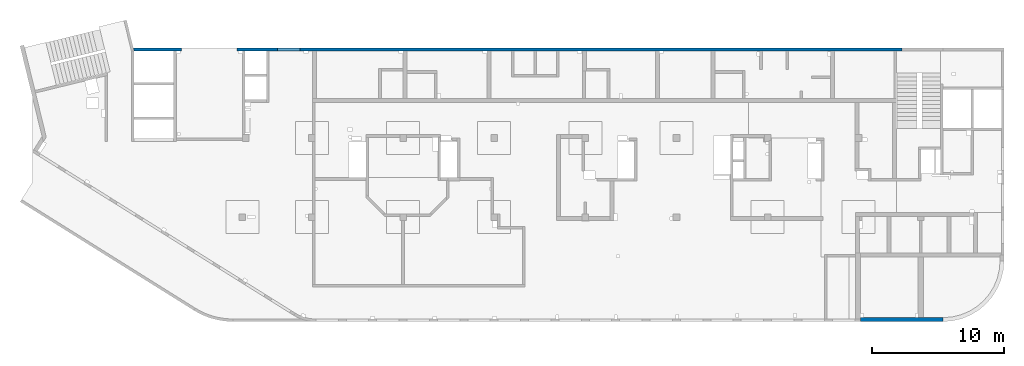
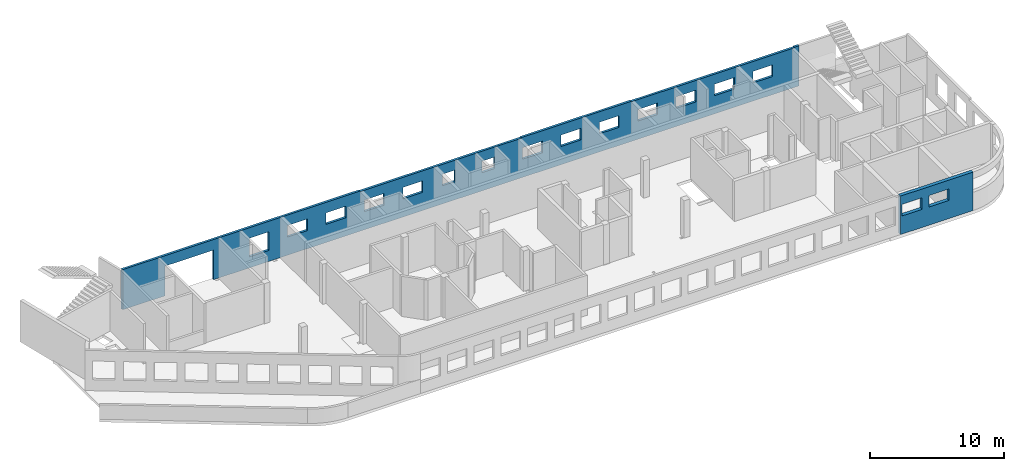
# One storey, part 9 of 10: 2 walls, 17 openings.
"""IFC4 building model written with IfcOpenShell, lengths in millimetres."""

import ifcopenshell
import ifcopenshell.guid

model = None  # the IFC model being written
_history = None  # IfcOwnerHistory: only IFC2X3 demands one
_inside = {}  # id of a spatial element -> (the spatial element, [elements in it])
_under = {}  # id of a project, library or spatial element -> (it, [spatial elements below it])
_declared = {}  # id of a project -> (the project, [libraries it declares])
_typed = {}  # id of a type object -> (the type object, [elements of that type])
_made_of = {}  # id of a material, layer set ... -> (it, [elements and type objects made of it])


def new_model(schema):
    """Start an empty IFC model of exactly this schema.

    Asked for "IFC4X3", IfcOpenShell would pick the latest addendum, in which some entities
    have other attributes; the version numbers below select the first issue.
    IFC2X3 requires an IfcOwnerHistory on every rooted entity: one is made here for all.
    """
    global model, _history
    if schema == "IFC4X3":
        model = ifcopenshell.file(schema_version=(4, 3, 0, 0))
    else:
        model = ifcopenshell.file(schema=schema)
    _inside.clear()
    _under.clear()
    _declared.clear()
    _typed.clear()
    _made_of.clear()
    _history = None
    if model.schema == "IFC2X3":
        org = make("IfcOrganization", Name="unknown")
        user = make(
            "IfcPersonAndOrganization",
            ThePerson=make("IfcPerson", FamilyName="unknown"),
            TheOrganization=org,
        )
        app = make(
            "IfcApplication",
            ApplicationDeveloper=org,
            Version="unknown",
            ApplicationFullName="unknown",
            ApplicationIdentifier="unknown",
        )
        _history = make(
            "IfcOwnerHistory",
            OwningUser=user,
            OwningApplication=app,
            ChangeAction="ADDED",
            CreationDate=0,
        )
    return model


def make(cls, **values):
    """One entity of the class cls with the attributes given. An attribute that is None is left unset."""
    return model.create_entity(
        cls, **{name: value for name, value in values.items() if value is not None}
    )


def entity(cls, *values):
    """Any entity or typed value of the class cls, its attributes in the order of the schema. None: left unset."""
    e = model.create_entity(cls)
    for i, value in enumerate(values):
        if value is not None:
            e[i] = value
    return e


def rooted(cls, **values):
    """An entity with a GlobalId (a new one), such as an element, a storey or a relation."""
    return make(cls, GlobalId=ifcopenshell.guid.new(), OwnerHistory=_history, **values)


def si_unit(unit_type, name, prefix=None):
    """IfcSIUnit, for example si_unit("LENGTHUNIT", "METRE", prefix="MILLI")."""
    return make("IfcSIUnit", UnitType=unit_type, Prefix=prefix, Name=name)


def converted_unit(unit_type, name, factor, base, dimensions=None, offset=None):
    """IfcConversionBasedUnit, such as the inch: factor (a typed value) times the base unit."""
    return make(
        "IfcConversionBasedUnit"
        if offset is None
        else "IfcConversionBasedUnitWithOffset",
        ConversionOffset=offset,
        Dimensions=None
        if dimensions is None
        else entity("IfcDimensionalExponents", *dimensions),
        UnitType=unit_type,
        Name=name,
        ConversionFactor=make(
            "IfcMeasureWithUnit", ValueComponent=factor, UnitComponent=base
        ),
    )


def derived_unit(unit_type, elements):
    """IfcDerivedUnit: a product of units, each with its exponent."""
    return make(
        "IfcDerivedUnit",
        Elements=[
            make("IfcDerivedUnitElement", Unit=unit, Exponent=power)
            for unit, power in elements
        ],
        UnitType=unit_type,
    )


def assignment(units):
    """IfcUnitAssignment: the units of a project."""
    return None if units is None else make("IfcUnitAssignment", Units=units)


def point(xyz):
    """IfcCartesianPoint."""
    return None if xyz is None else make("IfcCartesianPoint", Coordinates=xyz)


def direction(xyz):
    """IfcDirection."""
    return None if xyz is None else make("IfcDirection", DirectionRatios=xyz)


def frame(location, z_axis=None, x_axis=None):
    """IfcAxis2Placement3D, a coordinate frame: its origin and axes. An axis left out is left unset."""
    return make(
        "IfcAxis2Placement3D",
        Location=point(location),
        Axis=direction(z_axis),
        RefDirection=direction(x_axis),
    )


def origin():
    """The frame at (0, 0, 0) with its axes left unset."""
    return frame((0.0, 0.0, 0.0))


def place(relative_to, where):
    """IfcLocalPlacement: puts the frame where relative to a parent placement (None: the world)."""
    return make(
        "IfcLocalPlacement", PlacementRelTo=relative_to, RelativePlacement=where
    )


def context(
    kind, dimensions, precision=None, world=None, true_north=None, identifier=None
):
    """IfcGeometricRepresentationContext, for example the 3D "Model" context."""
    return make(
        "IfcGeometricRepresentationContext",
        ContextIdentifier=identifier,
        ContextType=kind,
        CoordinateSpaceDimension=dimensions,
        Precision=precision,
        WorldCoordinateSystem=world,
        TrueNorth=true_north,
    )


def subcontext(parent, identifier, kind, view, scale=None):
    """IfcGeometricRepresentationSubContext, for example "Body" below "Model"."""
    return make(
        "IfcGeometricRepresentationSubContext",
        ContextIdentifier=identifier,
        ContextType=kind,
        ParentContext=parent,
        TargetScale=scale,
        TargetView=view,
    )


def project(units=None, contexts=None):
    """IfcProject with its units and contexts."""
    return rooted(
        "IfcProject",
        Name="project",
        RepresentationContexts=contexts,
        UnitsInContext=assignment(units),
    )


def spatial(cls, under=None, at=None, **own):
    """A site, building, storey or space (cls), placed at a placement, below another one or the project."""
    s = rooted(cls, ObjectPlacement=at, **own)
    if under is not None:
        _under.setdefault(under.id(), (under, []))[1].append(s)
    return s


def point_list(points):
    """IfcCartesianPointList2D or 3D."""
    cls = (
        "IfcCartesianPointList2D" if len(points[0]) == 2 else "IfcCartesianPointList3D"
    )
    return make(cls, CoordList=points)


def indexed_curve(points, segments=None, self_intersect=None):
    """IfcIndexedPolyCurve: lines and arcs through numbered points (the first is 1)."""
    return make(
        "IfcIndexedPolyCurve",
        Points=point_list(points),
        Segments=segments,
        SelfIntersect=self_intersect,
    )


def outline(outer, holes=None, kind="AREA"):
    """IfcArbitraryClosedProfileDef: a profile drawn as a closed curve; with holes, ...WithVoids."""
    if holes is None:
        return make("IfcArbitraryClosedProfileDef", ProfileType=kind, OuterCurve=outer)
    return make(
        "IfcArbitraryProfileDefWithVoids",
        ProfileType=kind,
        OuterCurve=outer,
        InnerCurves=holes,
    )


def extrude(swept, where, along, depth):
    """IfcExtrudedAreaSolid: the profile swept, set in the frame where, extruded along a direction by depth."""
    return make(
        "IfcExtrudedAreaSolid",
        SweptArea=swept,
        Position=where,
        ExtrudedDirection=direction(along),
        Depth=depth,
    )


def polygons(points, faces, closed=None, point_numbers=None):
    """IfcPolygonalFaceSet: a face is its outer loop, then its inner loops; points numbered from 1."""
    made = []
    for loops in faces:
        if len(loops) == 1:
            made.append(make("IfcIndexedPolygonalFace", CoordIndex=loops[0]))
        else:
            made.append(
                make(
                    "IfcIndexedPolygonalFaceWithVoids",
                    CoordIndex=loops[0],
                    InnerCoordIndices=loops[1:],
                )
            )
    return make(
        "IfcPolygonalFaceSet",
        Coordinates=point_list(points),
        Closed=closed,
        Faces=made,
        PnIndex=point_numbers,
    )


def shape(context_of_items, identifier, shape_type, items):
    """IfcShapeRepresentation: the items that make up one representation, for example the "Body"."""
    return make(
        "IfcShapeRepresentation",
        ContextOfItems=context_of_items,
        RepresentationIdentifier=identifier,
        RepresentationType=shape_type,
        Items=items,
    )


def material(Name=None, Category=None):
    """IfcMaterial."""
    return make("IfcMaterial", Name=Name, Category=Category)


def made_of(thing, what):
    """Note that an element or type object is made of a material, layer set ...; save() writes the relation."""
    if what is not None:
        _made_of.setdefault(what.id(), (what, []))[1].append(thing)
    return thing


def type_object(cls, material=None, **own):
    """A type object (cls), such as IfcWallType, which elements share."""
    return made_of(rooted(cls, **own), material)


def element(
    cls,
    number,
    at=None,
    inside=None,
    cuts=None,
    type_object=None,
    material=None,
    context=None,
    identifier="Body",
    shape_type=None,
    held_by="IfcProductDefinitionShape",
    body=None,
    shapes=None,
    **own,
):
    """One element of the class cls, such as IfcWall. Its Tag is "e" and its number.

    at: its placement. inside: the storey or other place that contains it. cuts: it is an
    opening in that element (IfcRelVoidsElement). A single representation is given by context,
    identifier, shape_type and body (its items); several are given by shapes. held_by: the class
    of the entity that holds the representations. save() writes the other relations.
    """
    e = rooted(cls, Tag="e%d" % number, ObjectPlacement=at, **own)
    if body is not None:
        shapes = [shape(context, identifier, shape_type, body)]
    if shapes is not None:
        e.Representation = make(held_by, Representations=shapes)
    if inside is not None:
        _inside.setdefault(inside.id(), (inside, []))[1].append(e)
    if cuts is not None:
        rooted(
            "IfcRelVoidsElement", RelatingBuildingElement=cuts, RelatedOpeningElement=e
        )
    if type_object is not None:
        _typed.setdefault(type_object.id(), (type_object, []))[1].append(e)
    return made_of(e, material)


def aggregate(whole, parts):
    """IfcRelAggregates: a whole, such as a stair, and the parts it consists of."""
    return rooted("IfcRelAggregates", RelatingObject=whole, RelatedObjects=parts)


def save(model, path):
    """Write the relations noted so far, then the file.

    IfcRelAggregates (storeys below a building ...), IfcRelContainedInSpatialStructure (elements
    in a storey), IfcRelDefinesByType, IfcRelAssociatesMaterial and IfcRelDeclares: one each for
    every whole, place, type object, material and project.
    """
    for whole, parts in _under.values():
        aggregate(whole, parts)
    for where, things in _inside.values():
        rooted(
            "IfcRelContainedInSpatialStructure",
            RelatedElements=things,
            RelatingStructure=where,
        )
    for kind, things in _typed.values():
        rooted("IfcRelDefinesByType", RelatedObjects=things, RelatingType=kind)
    for what, things in _made_of.values():
        rooted("IfcRelAssociatesMaterial", RelatedObjects=things, RelatingMaterial=what)
    for by, libraries in _declared.values():
        rooted("IfcRelDeclares", RelatingContext=by, RelatedDefinitions=libraries)
    model.write(path)


model = new_model("IFC4")

# Units and contexts
model_context = context("Model", 3, precision=0.01, world=origin(), true_north=direction((6.12303176911189e-17, 1.0)))
plan_context = context("Plan", 3, precision=0.01, world=origin(), true_north=direction((6.12303176911189e-17, 1.0)))
body_context = subcontext(model_context, "Body", "Model", "MODEL_VIEW")
ifc_project = project(units=[si_unit("LENGTHUNIT", "METRE", prefix="MILLI"), si_unit("AREAUNIT", "SQUARE_METRE"), si_unit("VOLUMEUNIT", "CUBIC_METRE"), converted_unit("PLANEANGLEUNIT", "DEGREE", entity("IfcRatioMeasure", 0.0174532925199433), si_unit("PLANEANGLEUNIT", "RADIAN"), dimensions=[0, 0, 0, 0, 0, 0, 0]), si_unit("MASSUNIT", "GRAM", prefix="KILO"), derived_unit("MASSDENSITYUNIT", [(si_unit("MASSUNIT", "GRAM", prefix="KILO"), 1), (si_unit("LENGTHUNIT", "METRE"), -3)]), derived_unit("MOMENTOFINERTIAUNIT", [(si_unit("LENGTHUNIT", "METRE"), 4)]), si_unit("TIMEUNIT", "SECOND"), si_unit("FREQUENCYUNIT", "HERTZ"), si_unit("THERMODYNAMICTEMPERATUREUNIT", "DEGREE_CELSIUS"), derived_unit("THERMALTRANSMITTANCEUNIT", [(si_unit("MASSUNIT", "GRAM", prefix="KILO"), 1), (si_unit("THERMODYNAMICTEMPERATUREUNIT", "KELVIN"), -1), (si_unit("TIMEUNIT", "SECOND"), -3)]), derived_unit("VOLUMETRICFLOWRATEUNIT", [(si_unit("LENGTHUNIT", "METRE"), 3), (si_unit("TIMEUNIT", "SECOND"), -1)]), derived_unit("MASSFLOWRATEUNIT", [(si_unit("MASSUNIT", "GRAM", prefix="KILO"), 1), (si_unit("TIMEUNIT", "SECOND"), -1)]), derived_unit("ROTATIONALFREQUENCYUNIT", [(si_unit("TIMEUNIT", "SECOND"), -1)]), si_unit("ELECTRICCURRENTUNIT", "AMPERE"), si_unit("ELECTRICVOLTAGEUNIT", "VOLT"), si_unit("POWERUNIT", "WATT"), si_unit("FORCEUNIT", "NEWTON", prefix="KILO"), si_unit("ILLUMINANCEUNIT", "LUX"), si_unit("LUMINOUSFLUXUNIT", "LUMEN"), si_unit("LUMINOUSINTENSITYUNIT", "CANDELA"), derived_unit("USERDEFINED", [(si_unit("MASSUNIT", "GRAM", prefix="KILO"), -1), (si_unit("LENGTHUNIT", "METRE"), -2), (si_unit("TIMEUNIT", "SECOND"), 3), (si_unit("LUMINOUSFLUXUNIT", "LUMEN"), 1)]), derived_unit("LINEARVELOCITYUNIT", [(si_unit("LENGTHUNIT", "METRE"), 1), (si_unit("TIMEUNIT", "SECOND"), -1)]), si_unit("PRESSUREUNIT", "PASCAL"), derived_unit("USERDEFINED", [(si_unit("LENGTHUNIT", "METRE"), -2), (si_unit("MASSUNIT", "GRAM", prefix="KILO"), 1), (si_unit("TIMEUNIT", "SECOND"), -2)]), derived_unit("LINEARFORCEUNIT", [(si_unit("MASSUNIT", "GRAM", prefix="KILO"), 1), (si_unit("LENGTHUNIT", "METRE"), 1), (si_unit("TIMEUNIT", "SECOND"), -2), (si_unit("LENGTHUNIT", "METRE"), -1)]), derived_unit("PLANARFORCEUNIT", [(si_unit("MASSUNIT", "GRAM", prefix="KILO"), 1), (si_unit("LENGTHUNIT", "METRE"), 1), (si_unit("TIMEUNIT", "SECOND"), -2), (si_unit("LENGTHUNIT", "METRE"), -2)])], contexts=[model_context, plan_context])

# Site, building, storey
site_placement = place(None, origin())
site = spatial("IfcSite", under=ifc_project, at=site_placement, CompositionType="ELEMENT")
building_placement = place(site_placement, origin())
building = spatial("IfcBuilding", under=site, at=building_placement, CompositionType="ELEMENT")
storey_placement = place(building_placement, frame((0.0, 0.0, 4200.0)))
storey = spatial("IfcBuildingStorey", under=building, at=storey_placement, Name="02", CompositionType="ELEMENT", Elevation=4200.0)

# Wall, openings
ifc_material = material()
wall_type_1 = type_object("IfcWallType", Name=":ADSK_ 25_200", PredefinedType="STANDARD")
wall_1_placement = place(storey_placement, frame((7650.64, 20400.0, -150.0)))
wall_1 = element("IfcWall", 1, at=wall_1_placement, inside=storey, type_object=wall_type_1, material=ifc_material, Name=":ADSK_ 25_200", ObjectType=":ADSK_ 25_200", PredefinedType="NOTDEFINED", context=body_context, shape_type="Tessellation", body=[
    polygons([(58179.3554564899, -99.9999999999989, 5.41433564649196e-13), (58179.3554564899, -99.9999999999989, 3650.0), (57779.3554564899, -99.9999999999989, 3650.0), (57779.3554564899, -99.9999999999989, 3600.0), (57579.3554564899, -99.9999999999989, 3600.0), (53069.3554564899, -99.9999999999989, 3600.0), (52769.3554564899, -99.9999999999989, 3600.0), (52629.3554564899, -99.9999999999989, 3600.0), (52429.3554564898, -99.9999999999989, 3600.0), (49619.3554564899, -99.9999999999989, 3600.0), (49419.3554564899, -99.9999999999989, 3600.0), (47619.3554564899, -99.9999999999989, 3600.0), (47419.3554564899, -99.9999999999989, 3600.0), (47219.3554564898, -99.9999999999989, 3600.0), (44039.3554564899, -99.9999999999989, 3600.0), (43739.3554564901, -99.9999999999989, 3600.0), (43739.3554564901, -99.9999999999989, 3650.0), (39819.3554564899, -99.9999999999989, 3650.0), (39519.3554564899, -99.9999999999989, 3650.0), (34319.3554564899, -99.9999999999989, 3650.0), (34319.3554564899, -99.9999999999989, 3600.0), (34019.3554564899, -99.9999999999989, 3600.0), (32219.3554564899, -99.9999999999989, 3600.0), (32019.3554564899, -99.9999999999989, 3600.0), (30519.3554564899, -99.9999999999989, 3600.0), (30319.3554564899, -99.9999999999989, 3600.0), (28819.3554564899, -99.9999999999989, 3600.0), (28619.3554564899, -99.9999999999989, 3600.0), (27069.3554564899, -99.9999999999989, 3600.0), (26769.3554564899, -99.9999999999989, 3600.0), (20719.3554564899, -99.9999999999989, 3600.0), (20419.3554564899, -99.9999999999989, 3600.0), (20419.3554564899, -99.9999999999989, 3650.0), (13869.3554564899, -99.9999999999989, 3650.0), (13569.3554564899, -99.9999999999989, 3650.0), (10274.3554564899, -99.9999999999989, 3650.0), (10074.3554564899, -99.9999999999989, 3650.0), (8449.3554564899, -99.9999999999989, 3650.0), (8249.3554564899, -99.9999999999989, 3650.0), (3249.35545648991, -99.9999999999989, 3650.0), (3049.35545648991, -99.9999999999989, 3650.0), (49.3554564899164, -99.9999999999989, 3650.0), (48.7521159583277, -99.9999999999989, 3650.0), (48.7521159583299, -99.9999999999989, 5.41433564649196e-13), (3049.35545648991, -99.9999999999989, 5.41433564649196e-13), (3249.35545648991, -99.9999999999989, 5.41433564649196e-13), (3549.35545648986, -99.9999999999989, 5.41433564649196e-13), (3649.35545648994, -99.9999999999989, 5.41433564649196e-13), (3649.35545648994, -99.9999999999989, 2699.99999999804), (7849.35545648994, -99.9999999999989, 2699.99999999804), (7849.35545648994, -99.9999999999989, 5.41433564649196e-13), (7949.35545648986, -99.9999999999989, 5.41433564649196e-13), (8249.35545648991, -99.9999999999989, 5.41433564649196e-13), (8449.3554564899, -99.9999999999989, 5.41433564649196e-13), (10074.3554564899, -99.9999999999989, 5.41433564649196e-13), (10274.3554564899, -99.9999999999989, 5.41433564649196e-13), (12919.3554564898, -99.9999999999989, 5.41433564649196e-13), (13219.3554564898, -99.9999999999989, 5.41433564649196e-13), (13569.3554564899, -99.9999999999989, 5.41433564649196e-13), (13869.3554564899, -99.9999999999989, 5.41433564649196e-13), (20119.3554564898, -99.9999999999989, 5.41433564649196e-13), (20419.3554564899, -99.9999999999989, 5.41433564649196e-13), (20719.3554564899, -99.9999999999989, 5.41433564649196e-13), (26469.3554564898, -99.9999999999989, 5.41433564649196e-13), (26769.3554564899, -99.9999999999989, 5.41433564649196e-13), (27069.3554564899, -99.9999999999989, 5.41433564649196e-13), (28619.3554564899, -99.9999999999989, 5.41433564649196e-13), (28819.3554564899, -99.9999999999989, 5.41433564649196e-13), (30319.3554564899, -99.9999999999989, 5.41433564649196e-13), (30519.3554564899, -99.9999999999989, 5.41433564649196e-13), (32019.3554564899, -99.9999999999989, 5.41433564649196e-13), (32219.3554564899, -99.9999999999989, 5.41433564649196e-13), (33619.3554564899, -99.9999999999989, 5.41433564649196e-13), (33919.3554564899, -99.9999999999989, 5.41433564649196e-13), (34019.3554564899, -99.9999999999989, 5.41433564649196e-13), (34319.3554564899, -99.9999999999989, 5.41433564649196e-13), (39519.3554564899, -99.9999999999989, 5.41433564649196e-13), (39819.3554564899, -99.9999999999989, 5.41433564649196e-13), (40119.3554564899, -99.9999999999989, 5.41433564649196e-13), (43739.3554564899, -99.9999999999989, 5.41433564649196e-13), (44039.3554564899, -99.9999999999989, 5.41433564649196e-13), (47419.3554564899, -99.9999999999989, 5.41433564649196e-13), (47619.3554564899, -99.9999999999989, 5.41433564649196e-13), (49419.3554564899, -99.9999999999989, 5.41433564649196e-13), (49619.3554564899, -99.9999999999989, 5.41433564649196e-13), (52769.3554564899, -99.9999999999989, 5.41433564649196e-13), (53069.3554564899, -99.9999999999989, 5.41433564649196e-13), (57579.3554564899, -99.9999999999989, 5.41433564649196e-13), (57779.3554564899, -99.9999999999989, 5.41433564649196e-13), (27519.3554564899, -99.9999999999989, 2700.0), (28619.3554564899, -99.9999999999989, 2700.0), (28619.3554564899, -99.9999999999989, 1650.00000000001), (27519.3554564899, -99.9999999999989, 1650.00000000001), (54219.3554564899, -99.9999999999989, 2700.0), (55919.3554564899, -99.9999999999989, 2700.0), (55919.3554564899, -99.9999999999989, 1650.00000000001), (54219.3554564899, -99.9999999999989, 1650.00000000001), (50919.3554564899, -99.9999999999989, 2700.0), (52619.3554564899, -99.9999999999989, 2700.0), (52619.3554564899, -99.9999999999989, 1650.00000000001), (50919.3554564899, -99.9999999999989, 1650.00000000001), (47619.3554564899, -99.9999999999989, 2700.0), (49319.3554564899, -99.9999999999989, 2700.0), (49319.3554564899, -99.9999999999989, 1650.00000000001), (47619.3554564899, -99.9999999999989, 1650.00000000001), (44319.3554564899, -99.9999999999989, 2700.0), (46019.3554564899, -99.9999999999989, 2700.0), (46019.3554564899, -99.9999999999989, 1650.00000000001), (44319.3554564899, -99.9999999999989, 1650.00000000001), (41019.3554564899, -99.9999999999989, 2700.0), (42719.3554564899, -99.9999999999989, 2700.0), (42719.3554564899, -99.9999999999989, 1650.00000000001), (41019.3554564899, -99.9999999999989, 1650.00000000001), (37719.3554564899, -99.9999999999989, 2700.0), (39419.3554564899, -99.9999999999989, 2700.0), (39419.3554564899, -99.9999999999989, 1650.00000000001), (37719.3554564899, -99.9999999999989, 1650.00000000001), (34419.3554564899, -99.9999999999946, 2700.0), (36119.3554564899, -99.9999999999989, 2700.0), (36119.3554564899, -99.9999999999989, 1650.00000000001), (34419.3554564899, -99.9999999999946, 1650.00000000001), (30919.3554564899, -99.9999999999989, 2700.0), (32019.3554564899, -99.9999999999989, 2700.0), (32019.3554564899, -99.9999999999989, 1650.00000000001), (30919.3554564899, -99.9999999999989, 1650.00000000001), (24119.3554564899, -99.9999999999989, 2700.0), (25819.3554564899, -99.9999999999989, 2700.0), (25819.3554564899, -99.9999999999989, 1650.00000000001), (24119.3554564899, -99.9999999999989, 1650.00000000001), (20819.3554564899, -99.9999999999989, 2700.0), (22519.3554564899, -99.9999999999989, 2700.0), (22519.3554564899, -99.9999999999989, 1650.00000000001), (20819.3554564899, -99.9999999999989, 1650.00000000001), (17519.3554564899, -99.9999999999989, 2700.0), (19219.3554564899, -100.000000000003, 2700.0), (19219.3554564899, -100.000000000003, 1650.00000000001), (17519.3554564899, -99.9999999999989, 1650.00000000001), (14219.3554564899, -99.9999999999989, 2700.0), (15919.3554564899, -99.9999999999989, 2700.0), (15919.3554564899, -99.9999999999989, 1650.00000000001), (14219.3554564899, -99.9999999999989, 1650.00000000001), (10919.3554564899, -99.9999999999989, 2700.0), (12619.3554564899, -99.9999999999989, 2700.0), (12619.3554564899, -99.9999999999989, 1000.00000000001), (10919.3554564899, -99.9999999999989, 1000.00000000001), (58179.3554564899, 99.9999999999989, 3650.0), (58179.3554564899, 99.9999999999989, 5.41433564649196e-13), (57779.3554564899, 99.9999999999989, 5.41433564649196e-13), (43739.3554564901, 99.9999999999989, 5.41433564649196e-13), (34319.3554564899, 99.9999999999989, 5.41433564649196e-13), (20419.3554564899, 99.9999999999989, 5.41433564649196e-13), (10074.3554564899, 99.9999999999989, 5.41433564649196e-13), (8449.35545648991, 99.9999999999989, 5.41433564649196e-13), (7849.35545648994, 99.9999999999989, 5.41433564649196e-13), (7849.35545648994, 99.9999999999989, 2699.99999999804), (3649.35545648994, 99.9999999999989, 2699.99999999804), (3649.35545648994, 99.9999999999989, 5.41433564649196e-13), (3049.35545648991, 99.9999999999989, 5.41433564649196e-13), (49.3554564899158, 99.9999999999989, 5.41433564649196e-13), (7.41714528604756e-14, 99.9999999999989, 5.41433564649196e-13), (1.15703858215887e-12, 99.9999999999989, 3650.0), (49.3554564899158, 99.9999999999989, 3650.0), (3049.35545648991, 99.9999999999989, 3650.0), (8449.35545648991, 99.9999999999989, 3650.0), (10074.3554564899, 99.9999999999989, 3650.0), (20419.3554564899, 99.9999999999989, 3650.0), (20419.3554564899, 99.9999999999989, 3600.0), (34319.3554564899, 99.9999999999989, 3600.0), (34319.3554564899, 99.9999999999989, 3650.0), (43739.3554564901, 99.9999999999989, 3650.0), (43739.3554564901, 99.9999999999903, 3600.0), (57779.3554564899, 99.9999999999903, 3600.0), (57779.3554564899, 99.9999999999989, 3650.0), (28619.3554564899, 100.000000000319, 2699.99999999999), (27519.3554564899, 100.000000000319, 2699.99999999999), (27519.3554564899, 100.000000000319, 1650.00000000001), (28619.3554564899, 100.000000000319, 1650.00000000001), (55919.3554564899, 100.000000000324, 2700.0), (54219.3554564899, 100.000000000324, 2700.0), (54219.3554564899, 100.000000000324, 1650.00000000001), (55919.3554564899, 100.000000000324, 1650.00000000001), (52619.3554564899, 100.000000000319, 2700.0), (50919.3554564899, 100.000000000324, 2700.0), (50919.3554564899, 100.000000000324, 1650.00000000001), (52619.3554564899, 100.000000000319, 1650.00000000001), (49319.3554564899, 100.000000000319, 2700.0), (47619.3554564899, 100.000000000324, 2700.0), (47619.3554564899, 100.000000000324, 1650.00000000001), (49319.3554564899, 100.000000000319, 1650.00000000001), (46019.3554564899, 100.000000000319, 2700.0), (44319.3554564899, 100.000000000319, 2700.0), (44319.3554564899, 100.000000000319, 1650.00000000001), (46019.3554564899, 100.000000000319, 1650.00000000001), (42719.3554564899, 100.000000000319, 2700.0), (41019.3554564899, 100.000000000319, 2700.0), (41019.3554564899, 100.000000000319, 1650.00000000001), (42719.3554564899, 100.000000000319, 1650.00000000001), (39419.3554564899, 100.000000000324, 2700.0), (37719.3554564899, 100.000000000319, 2700.0), (37719.3554564899, 100.000000000319, 1650.00000000001), (39419.3554564899, 100.000000000324, 1650.00000000001), (36119.3554564899, 100.000000000319, 2700.0), (34419.3554564899, 100.000000000324, 2700.0), (34419.3554564899, 100.000000000324, 1650.00000000001), (36119.3554564899, 100.000000000319, 1650.00000000001), (32019.3554564899, 100.000000000319, 2699.99999999999), (30919.3554564899, 100.000000000319, 2699.99999999999), (30919.3554564899, 100.000000000319, 1650.00000000001), (32019.3554564899, 100.000000000319, 1650.00000000001), (25819.3554564899, 100.000000000319, 2699.99999999999), (24119.3554564899, 100.000000000324, 2699.99999999999), (24119.3554564899, 100.000000000324, 1650.00000000001), (25819.3554564899, 100.000000000319, 1650.00000000001), (22519.3554564899, 100.000000000319, 2699.99999999999), (20819.3554564899, 100.000000000324, 2699.99999999999), (20819.3554564899, 100.000000000324, 1650.00000000001), (22519.3554564899, 100.000000000319, 1650.00000000001), (19219.3554564899, 100.000000000319, 2699.99999999999), (17519.3554564899, 100.000000000319, 2699.99999999999), (17519.3554564899, 100.000000000319, 1650.00000000001), (19219.3554564899, 100.000000000319, 1650.00000000001), (15919.3554564899, 100.000000000319, 2699.99999999999), (14219.3554564899, 100.000000000319, 2699.99999999999), (14219.3554564899, 100.000000000319, 1650.00000000001), (15919.3554564899, 100.000000000319, 1650.00000000001), (12619.3554564899, 100.000000000319, 2700.0), (10919.3554564899, 100.000000000319, 2700.0), (10919.3554564899, 100.000000000319, 1000.00000000001), (12619.3554564899, 100.000000000319, 1000.00000000001)], [[[1, 2, 3, 4, 5, 6, 7, 8, 9, 10, 11, 12, 13, 14, 15, 16, 17, 18, 19, 20, 21, 22, 23, 24, 25, 26, 27, 28, 29, 30, 31, 32, 33, 34, 35, 36, 37, 38, 39, 40, 41, 42, 43, 44, 45, 46, 47, 48, 49, 50, 51, 52, 53, 54, 55, 56, 57, 58, 59, 60, 61, 62, 63, 64, 65, 66, 67, 68, 69, 70, 71, 72, 73, 74, 75, 76, 77, 78, 79, 80, 81, 82, 83, 84, 85, 86, 87, 88, 89], [90, 91, 92, 93], [94, 95, 96, 97], [98, 99, 100, 101], [102, 103, 104, 105], [106, 107, 108, 109], [110, 111, 112, 113], [114, 115, 116, 117], [118, 119, 120, 121], [122, 123, 124, 125], [126, 127, 128, 129], [130, 131, 132, 133], [134, 135, 136, 137], [138, 139, 140, 141], [142, 143, 144, 145]], [[146, 147, 148, 149, 150, 151, 152, 153, 154, 155, 156, 157, 158, 159, 160, 161, 162, 163, 164, 165, 166, 167, 168, 169, 170, 171, 172, 173], [174, 175, 176, 177], [178, 179, 180, 181], [182, 183, 184, 185], [186, 187, 188, 189], [190, 191, 192, 193], [194, 195, 196, 197], [198, 199, 200, 201], [202, 203, 204, 205], [206, 207, 208, 209], [210, 211, 212, 213], [214, 215, 216, 217], [218, 219, 220, 221], [222, 223, 224, 225], [226, 227, 228, 229]], [[44, 160, 159, 158, 157, 48, 47, 46, 45]], [[2, 1, 147, 146]], [[44, 43, 161, 160]], [[165, 164, 38, 37]], [[2, 146, 173, 3]], [[163, 162, 42, 41]], [[33, 32, 167, 166]], [[169, 168, 21, 20]], [[43, 42, 162, 161]], [[41, 40, 39, 38, 164, 163]], [[165, 37, 36, 35, 34, 33, 166]], [[20, 19, 18, 17, 170, 169]], [[32, 31, 30, 29, 28, 27, 26, 25, 24, 23, 22, 21, 168, 167]], [[175, 174, 91, 90]], [[175, 90, 93, 176]], [[176, 93, 92, 177]], [[91, 174, 177, 92]], [[179, 178, 95, 94]], [[179, 94, 97, 180]], [[180, 97, 96, 181]], [[95, 178, 181, 96]], [[183, 182, 99, 98]], [[183, 98, 101, 184]], [[184, 101, 100, 185]], [[99, 182, 185, 100]], [[187, 186, 103, 102]], [[187, 102, 105, 188]], [[188, 105, 104, 189]], [[103, 186, 189, 104]], [[191, 190, 107, 106]], [[191, 106, 109, 192]], [[192, 109, 108, 193]], [[107, 190, 193, 108]], [[195, 194, 111, 110]], [[195, 110, 113, 196]], [[196, 113, 112, 197]], [[111, 194, 197, 112]], [[199, 198, 115, 114]], [[199, 114, 117, 200]], [[200, 117, 116, 201]], [[115, 198, 201, 116]], [[203, 202, 119, 118]], [[203, 118, 121, 204]], [[204, 121, 120, 205]], [[119, 202, 205, 120]], [[207, 206, 123, 122]], [[207, 122, 125, 208]], [[208, 125, 124, 209]], [[123, 206, 209, 124]], [[211, 210, 127, 126]], [[211, 126, 129, 212]], [[212, 129, 128, 213]], [[127, 210, 213, 128]], [[215, 214, 131, 130]], [[215, 130, 133, 216]], [[216, 133, 132, 217]], [[131, 214, 217, 132]], [[219, 218, 135, 134]], [[219, 134, 137, 220]], [[220, 137, 136, 221]], [[135, 218, 221, 136]], [[223, 222, 139, 138]], [[223, 138, 141, 224]], [[224, 141, 140, 225]], [[139, 222, 225, 140]], [[227, 226, 143, 142]], [[227, 142, 145, 228]], [[228, 145, 144, 229]], [[143, 226, 229, 144]], [[49, 156, 155, 50]], [[50, 155, 154, 51]], [[156, 49, 48, 157]], [[4, 172, 171, 16, 15, 14, 13, 12, 11, 10, 9, 8, 7, 6, 5]], [[16, 171, 170, 17]], [[172, 4, 3, 173]], [[147, 1, 89, 88, 87, 86, 85, 84, 83, 82, 81, 80, 79, 78, 77, 76, 75, 74, 73, 72, 71, 70, 69, 68, 67, 66, 65, 64, 63, 62, 61, 60, 59, 58, 57, 56, 55, 54, 53, 52, 51, 154, 153, 152, 151, 150, 149, 148]]], closed=True),
])
placement_1 = place(wall_1_placement, frame((-7650.64, -20400.0, 150.0)))
element("IfcOpeningElement", 2, at=placement_1, cuts=wall_1, Name=":ADSK_ 25_200", PredefinedType="OPENING", context=body_context, shape_type="SweptSolid", body=[
    extrude(outline(indexed_curve([(-524.999999999993, -550.000000000001), (524.999999999993, -550.000000000001), (524.999999999993, 550.000000000001), (-524.999999999993, 550.000000000001), (-524.999999999993, -550.000000000001)], self_intersect=False)), frame((35720.0, 20300.0, 2025.0), z_axis=(0.0, 1.0, 0.0), x_axis=(0.0, 0.0, -1.0)), (0.0, 0.0, 1.0), 200.000000000959),
])
element("IfcOpeningElement", 3, at=placement_1, cuts=wall_1, Name=":ADSK_ 25_200", PredefinedType="OPENING", context=body_context, shape_type="SweptSolid", body=[
    extrude(outline(indexed_curve([(-524.999999999993, -850.000000000006), (524.999999999993, -850.000000000006), (524.999999999993, 849.999999999997), (-524.999999999993, 849.999999999997), (-524.999999999993, -850.000000000006)], self_intersect=False)), frame((62720.0, 20300.0, 2025.0), z_axis=(0.0, 1.0, 0.0), x_axis=(0.0, 0.0, -1.0)), (0.0, 0.0, 1.0), 200.000000000959),
])
element("IfcOpeningElement", 4, at=placement_1, cuts=wall_1, Name=":ADSK_ 25_200", PredefinedType="OPENING", context=body_context, shape_type="SweptSolid", body=[
    extrude(outline(indexed_curve([(-524.999999999993, -850.000000000006), (524.999999999993, -850.000000000006), (524.999999999993, 849.999999999997), (-524.999999999993, 849.999999999997), (-524.999999999993, -850.000000000006)], self_intersect=False)), frame((59420.0, 20300.0, 2025.0), z_axis=(0.0, 1.0, 0.0), x_axis=(0.0, 0.0, -1.0)), (0.0, 0.0, 1.0), 200.000000000959),
])
element("IfcOpeningElement", 5, at=placement_1, cuts=wall_1, Name=":ADSK_ 25_200", PredefinedType="OPENING", context=body_context, shape_type="SweptSolid", body=[
    extrude(outline(indexed_curve([(-524.999999999993, -850.000000000006), (524.999999999993, -850.000000000006), (524.999999999993, 849.999999999997), (-524.999999999993, 849.999999999997), (-524.999999999993, -850.000000000006)], self_intersect=False)), frame((56120.0, 20300.0, 2025.0), z_axis=(0.0, 1.0, 0.0), x_axis=(0.0, 0.0, -1.0)), (0.0, 0.0, 1.0), 200.000000000959),
])
element("IfcOpeningElement", 6, at=placement_1, cuts=wall_1, Name=":ADSK_ 25_200", PredefinedType="OPENING", context=body_context, shape_type="SweptSolid", body=[
    extrude(outline(indexed_curve([(-524.999999999993, -849.999999999997), (524.999999999993, -849.999999999997), (524.999999999993, 850.000000000006), (-524.999999999993, 850.000000000006), (-524.999999999993, -849.999999999997)], self_intersect=False)), frame((52820.0, 20300.0, 2025.0), z_axis=(0.0, 1.0, 0.0), x_axis=(0.0, 0.0, -1.0)), (0.0, 0.0, 1.0), 200.000000000959),
])
element("IfcOpeningElement", 7, at=placement_1, cuts=wall_1, Name=":ADSK_ 25_200", PredefinedType="OPENING", context=body_context, shape_type="SweptSolid", body=[
    extrude(outline(indexed_curve([(-524.999999999993, -850.000000000006), (524.999999999993, -850.000000000006), (524.999999999993, 849.999999999997), (-524.999999999993, 849.999999999997), (-524.999999999993, -850.000000000006)], self_intersect=False)), frame((49520.0, 20300.0, 2025.0), z_axis=(0.0, 1.0, 0.0), x_axis=(0.0, 0.0, -1.0)), (0.0, 0.0, 1.0), 200.000000000959),
])
element("IfcOpeningElement", 8, at=placement_1, cuts=wall_1, Name=":ADSK_ 25_200", PredefinedType="OPENING", context=body_context, shape_type="SweptSolid", body=[
    extrude(outline(indexed_curve([(-524.999999999993, -850.000000000006), (524.999999999993, -850.000000000006), (524.999999999993, 849.999999999997), (-524.999999999993, 849.999999999997), (-524.999999999993, -850.000000000006)], self_intersect=False)), frame((46220.0, 20300.0, 2025.0), z_axis=(0.0, 1.0, 0.0), x_axis=(0.0, 0.0, -1.0)), (0.0, 0.0, 1.0), 200.000000000959),
])
element("IfcOpeningElement", 9, at=placement_1, cuts=wall_1, Name=":ADSK_ 25_200", PredefinedType="OPENING", context=body_context, shape_type="SweptSolid", body=[
    extrude(outline(indexed_curve([(-524.999999999993, -850.000000000006), (524.999999999993, -850.000000000006), (524.999999999993, 849.999999999997), (-524.999999999993, 849.999999999997), (-524.999999999993, -850.000000000006)], self_intersect=False)), frame((42920.0, 20300.0, 2025.0), z_axis=(0.0, 1.0, 0.0), x_axis=(0.0, 0.0, -1.0)), (0.0, 0.0, 1.0), 200.000000000959),
])
element("IfcOpeningElement", 10, at=placement_1, cuts=wall_1, Name=":ADSK_ 25_200", PredefinedType="OPENING", context=body_context, shape_type="SweptSolid", body=[
    extrude(outline(indexed_curve([(-524.999999999993, -549.999999999996), (524.999999999993, -549.999999999996), (524.999999999993, 550.000000000001), (-524.999999999993, 550.000000000001), (-524.999999999993, -549.999999999996)], self_intersect=False)), frame((39120.0, 20300.0, 2025.0), z_axis=(0.0, 1.0, 0.0), x_axis=(0.0, 0.0, -1.0)), (0.0, 0.0, 1.0), 200.000000000959),
])
element("IfcOpeningElement", 11, at=placement_1, cuts=wall_1, Name=":ADSK_ 25_200", PredefinedType="OPENING", context=body_context, shape_type="SweptSolid", body=[
    extrude(outline(indexed_curve([(-524.999999999993, -850.000000000002), (524.999999999993, -850.000000000002), (524.999999999993, 849.999999999997), (-524.999999999993, 849.999999999997), (-524.999999999993, -850.000000000002)], self_intersect=False)), frame((32620.0, 20300.0, 2025.0), z_axis=(0.0, 1.0, 0.0), x_axis=(0.0, 0.0, -1.0)), (0.0, 0.0, 1.0), 200.000000000959),
])
element("IfcOpeningElement", 12, at=placement_1, cuts=wall_1, Name=":ADSK_ 25_200", PredefinedType="OPENING", context=body_context, shape_type="SweptSolid", body=[
    extrude(outline(indexed_curve([(-524.999999999993, -849.999999999997), (524.999999999993, -849.999999999997), (524.999999999993, 850.000000000002), (-524.999999999993, 850.000000000002), (-524.999999999993, -849.999999999997)], self_intersect=False)), frame((29320.0, 20300.0, 2025.0), z_axis=(0.0, 1.0, 0.0), x_axis=(0.0, 0.0, -1.0)), (0.0, 0.0, 1.0), 200.000000000959),
])
element("IfcOpeningElement", 13, at=placement_1, cuts=wall_1, Name=":ADSK_ 25_200", PredefinedType="OPENING", context=body_context, shape_type="SweptSolid", body=[
    extrude(outline(indexed_curve([(-524.999999999993, -850.000000000002), (524.999999999993, -850.000000000002), (524.999999999993, 849.999999999997), (-524.999999999993, 849.999999999997), (-524.999999999993, -850.000000000002)], self_intersect=False)), frame((26020.0, 20300.0, 2025.0), z_axis=(0.0, 1.0, 0.0), x_axis=(0.0, 0.0, -1.0)), (0.0, 0.0, 1.0), 200.000000000959),
])
element("IfcOpeningElement", 14, at=placement_1, cuts=wall_1, Name=":ADSK_ 25_200", PredefinedType="OPENING", context=body_context, shape_type="SweptSolid", body=[
    extrude(outline(indexed_curve([(-524.999999999993, -850.000000000002), (524.999999999993, -850.000000000002), (524.999999999993, 849.999999999997), (-524.999999999993, 849.999999999997), (-524.999999999993, -850.000000000002)], self_intersect=False)), frame((22720.0, 20300.0, 2025.0), z_axis=(0.0, 1.0, 0.0), x_axis=(0.0, 0.0, -1.0)), (0.0, 0.0, 1.0), 200.000000000959),
])
element("IfcOpeningElement", 15, at=placement_1, cuts=wall_1, Name=":ADSK_ 25_200", PredefinedType="OPENING", context=body_context, shape_type="SweptSolid", body=[
    extrude(outline(indexed_curve([(-849.999999999993, -850.000000000002), (849.999999999994, -850.000000000002), (849.999999999994, 850.0), (-849.999999999993, 850.0), (-849.999999999993, -850.000000000002)], self_intersect=False)), frame((19420.0, 20300.0, 1700.0), z_axis=(0.0, 1.0, 0.0), x_axis=(0.0, 0.0, -1.0)), (0.0, 0.0, 1.0), 200.000000000959),
])
element("IfcOpeningElement", 16, at=placement_1, cuts=wall_1, Name=":ADSK_ 25_200", PredefinedType="OPENING", context=body_context, shape_type="SweptSolid", body=[
    extrude(outline(indexed_curve([(-2100.0, -1349.99999999902), (2100.0, -1349.99999999902), (2100.0, 1349.99999999902), (-2100.0, 1349.99999999902), (-2100.0, -1349.99999999902)], self_intersect=False)), frame((13400.0, 20200.0, 1200.0), z_axis=(0.0, 1.0, 0.0), x_axis=(1.0, 0.0, 0.0)), (0.0, 0.0, 1.0), 400.000000001945),
])

wall_type_2 = type_object("IfcWallType", Name=":ADSK_ 25_300", PredefinedType="STANDARD")
wall_2_placement = place(storey_placement, frame((68970.0, -50.0, -150.0), z_axis=(0.0, 0.0, 1.0), x_axis=(-1.0, 0.0, 0.0)))
wall_2 = element("IfcWall", 17, at=wall_2_placement, inside=storey, type_object=wall_type_2, material=ifc_material, Name=":ADSK_ 25_300", ObjectType=":ADSK_ 25_300", PredefinedType="NOTDEFINED", context=body_context, shape_type="Tessellation", body=[
    polygons([(-8.34067231120643e-12, -150.0, 3500.0), (3.22264723180709e-13, -150.0, 2900.0), (3.22264723180709e-13, -150.0, 1650.0), (-8.34067231120643e-12, -150.0, 5.41433564649196e-13), (1499.99593014566, -150.0, 5.41433564649196e-13), (1899.99593014565, -150.0, 5.41433564649196e-13), (2099.99593014566, -150.0, 5.41433564649196e-13), (6049.99593014566, -150.0, 5.41433564649196e-13), (6249.99593014565, -150.0, 5.41433564649196e-13), (6249.99593014565, -150.0, 3500.0), (1899.99593014565, -150.0, 3500.0), (1499.99593014566, -150.0, 3500.0), (4399.99593014561, -150.000000000321, 2700.0), (6099.99593014561, -150.000000000321, 2700.0), (6099.99593014561, -150.000000000321, 1650.00000000001), (4399.99593014561, -150.000000000321, 1650.00000000001), (2099.99593014561, -150.000000000321, 2700.0), (3799.99593014561, -150.000000000321, 2700.0), (3799.99593014561, -150.000000000321, 1650.00000000001), (2099.99593014561, -150.000000000321, 1650.00000000001), (-9.30747396035053e-12, 150.0, 5.41433564649196e-13), (-6.44536925963393e-13, 150.0, 1650.0), (-6.44536925963393e-13, 150.0, 2900.0), (-9.30747396035053e-12, 150.0, 3500.0), (6249.99593014565, 150.0, 3500.0), (6249.99593014565, 150.0, 5.41433564649196e-13), (6099.9959301456, 150.0, 2700.0), (4399.99593014561, 150.0, 2700.0), (4399.99593014561, 150.0, 1650.00000000001), (6099.9959301456, 150.0, 1650.00000000001), (3799.99593014561, 150.0, 2700.0), (2099.99593014561, 150.0, 2700.0), (2099.99593014561, 150.0, 1650.00000000001), (3799.99593014561, 150.0, 1650.00000000001), (6249.99593014565, -50.0, 5.41433564649196e-13), (6249.99593014565, -50.0000000000001, 3500.0)], [[[1, 2, 3, 4, 5, 6, 7, 8, 9, 10, 11, 12], [13, 14, 15, 16], [17, 18, 19, 20]], [[21, 22, 23, 24, 25, 26], [27, 28, 29, 30], [31, 32, 33, 34]], [[9, 8, 7, 6, 5, 4, 21, 26, 35]], [[1, 12, 11, 10, 36, 25, 24]], [[1, 24, 23, 22, 21, 4, 3, 2]], [[10, 9, 35, 26, 25, 36]], [[14, 13, 28, 27]], [[14, 27, 30, 15]], [[15, 30, 29, 16]], [[28, 13, 16, 29]], [[18, 17, 32, 31]], [[18, 31, 34, 19]], [[19, 34, 33, 20]], [[32, 17, 20, 33]]], closed=True),
])
placement_2 = place(wall_2_placement, frame((68970.0, -50.0, 150.0), z_axis=(0.0, 0.0, 1.0), x_axis=(-1.0, 0.0, 0.0)))
element("IfcOpeningElement", 18, at=placement_2, cuts=wall_2, Name=":ADSK_ 25_300", PredefinedType="OPENING", context=body_context, shape_type="SweptSolid", body=[
    extrude(outline(indexed_curve([(-849.999999999997, -524.999999999992), (850.000000000006, -524.999999999992), (850.000000000006, 524.999999999993), (-849.999999999997, 524.999999999993), (-849.999999999997, -524.999999999992)], self_intersect=False)), frame((63720.0, 100.0, 2025.0), z_axis=(0.0, -1.0, 0.0), x_axis=(-1.0, 0.0, 0.0)), (0.0, 0.0, 1.0), 300.000000000962),
])
element("IfcOpeningElement", 19, at=placement_2, cuts=wall_2, Name=":ADSK_ 25_300", PredefinedType="OPENING", context=body_context, shape_type="SweptSolid", body=[
    extrude(outline(indexed_curve([(-849.999999999997, -524.999999999992), (850.000000000006, -524.999999999992), (850.000000000006, 524.999999999993), (-849.999999999997, 524.999999999993), (-849.999999999997, -524.999999999992)], self_intersect=False)), frame((66020.0, 100.0, 2025.0), z_axis=(0.0, -1.0, 0.0), x_axis=(-1.0, 0.0, 0.0)), (0.0, 0.0, 1.0), 300.000000000962),
])

save(model, "model.ifc")
